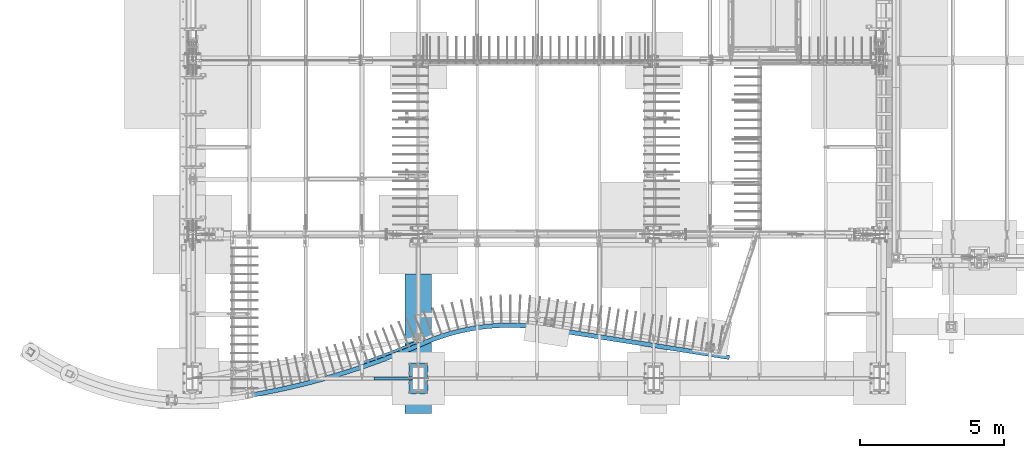
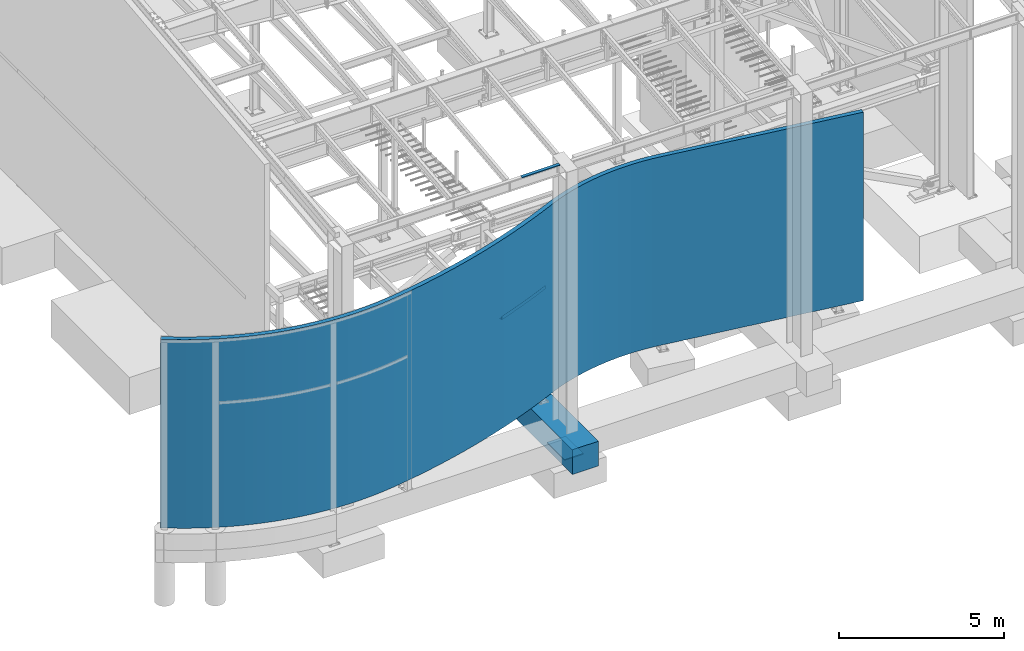
# One storey, part 704 of 1179: 5 beams, 5 elements without a shape of their own.
"""IFC2X3 building model written with IfcOpenShell, lengths in millimetres."""

from ifc_helpers import new_model, si_unit, frame, origin_with_axes, place, context, subcontext, project, spatial, faceted_brep, material, type_object, element, aggregate, save


model = new_model("IFC2X3")

# Units and contexts
model_context = context("Model", 3, precision=1e-05, world=origin_with_axes())
body_context = subcontext(model_context, "Body", "Model", "MODEL_VIEW")
ifc_project = project(units=[si_unit("LENGTHUNIT", "METRE", prefix="MILLI"), si_unit("AREAUNIT", "SQUARE_METRE"), si_unit("VOLUMEUNIT", "CUBIC_METRE"), si_unit("MASSUNIT", "GRAM", prefix="KILO"), si_unit("TIMEUNIT", "SECOND"), si_unit("PLANEANGLEUNIT", "RADIAN"), si_unit("SOLIDANGLEUNIT", "STERADIAN"), si_unit("THERMODYNAMICTEMPERATUREUNIT", "DEGREE_CELSIUS"), si_unit("LUMINOUSINTENSITYUNIT", "LUMEN")], contexts=[model_context])

# Site, building, storey
site_placement = place(None, origin_with_axes())
site = spatial("IfcSite", under=ifc_project, at=site_placement, CompositionType="ELEMENT")
building_placement = place(site_placement, origin_with_axes())
building = spatial("IfcBuilding", under=site, at=building_placement, Name="Undefined", CompositionType="ELEMENT")
storey_placement = place(building_placement, origin_with_axes())
storey = spatial("IfcBuildingStorey", under=building, at=storey_placement, Name="Undefined", CompositionType="ELEMENT", Elevation=0.0)

# Assembly, beam
assembly_1_placement = place(storey_placement, origin_with_axes())
assembly_1 = element("IfcElementAssembly", 1, at=assembly_1_placement, inside=storey, Name="BEAM", AssemblyPlace="NOTDEFINED", PredefinedType="RIGID_FRAME")
ifc_material_1 = material(Name="STEEL/A36")
beam_type_1 = type_object("IfcBeamType", PredefinedType="NOTDEFINED")
beam_1_placement = place(assembly_1_placement, frame((7404.09999999923, 485.774999119926, 9265.24531304499), z_axis=(-1.0, 0.0, 0.0), x_axis=(0.0, 0.0, 1.0)))
beam_1 = element("IfcBeam", 2, at=beam_1_placement, type_object=beam_type_1, material=ifc_material_1, Name="BENT_PLATE", context=body_context, shape_type="Brep", body=[
    faceted_brep([(-2.18278728425503e-11, -3.17500000000001, -663.575), (-2.18278728425503e-11, -3.17500000000001, 663.575), (2.18278728425503e-11, 3.17500000000001, 663.575), (2.18278728425503e-11, 3.17500000000001, -663.575), (36.8806648298032, 3.17499999974928, 663.575), (36.8806648298032, 3.17499999974928, -663.575), (29.7727112124448, -3.17500000020243, -663.575), (29.7727112124448, -3.17500000020243, 663.575), (25.3999996229504, -98.4249984738682, 663.575), (25.3999996229504, -98.4249984738682, -663.575), (19.7271291780035, -92.0749984738682, -663.575), (19.7271291780035, -92.0749984738682, 663.575), (9.29503585211933e-09, -98.4249984738682, 663.575), (9.29503585211933e-09, -98.4249984738682, -663.575), (9.29503585211933e-09, -92.0749984738682, 663.575), (9.29503585211933e-09, -92.0749984738682, -663.575)], [[[0, 1, 2, 3]], [[3, 2, 4, 5]], [[1, 0, 6, 7]], [[5, 4, 8, 9]], [[7, 6, 10, 11]], [[9, 8, 12, 13]], [[8, 4, 2, 1, 7, 11, 14, 12]], [[11, 10, 15, 14]], [[10, 6, 0, 3, 5, 9, 13, 15]], [[14, 15, 13, 12]]]),
])
aggregate(assembly_1, [beam_1])

assembly_2_placement = place(storey_placement, origin_with_axes())
assembly_2 = element("IfcElementAssembly", 3, at=assembly_2_placement, inside=storey, Name="BENT_PLATE", AssemblyPlace="NOTDEFINED", PredefinedType="RIGID_FRAME")
beam_type_2 = type_object("IfcBeamType", PredefinedType="NOTDEFINED")
beam_2_placement = place(assembly_2_placement, frame((8277.41144915615, 1723.22809377276, 3914.775), z_axis=(0.0, 0.0, 1.0), x_axis=(-0.925577876911731, -0.378557252963898, 0.0)))
beam_2 = element("IfcBeam", 4, at=beam_2_placement, type_object=beam_type_2, material=ifc_material_1, Name="BENT_PLATE", context=body_context, shape_type="Brep", body=[
    faceted_brep([(2.08746570688345, -50.7785532823825, -66.6750000000002), (2.08746570688345, -50.7785532823825, -60.3249999999998), (0.130466611703014, 44.4513404198469, -60.3249999999998), (0.130466611703014, 44.4513404198469, 66.6750000000002), (6.91215973347425e-11, 50.8000000000129, 66.6750000000002), (6.91215973347425e-11, 50.8000000000129, -66.6750000000002), (836.585317878429, 47.8884872559115, 66.6750000000002), (1254.74210741231, 39.2949292793146, 66.6750000000002), (1672.70114584619, 23.8290939184487, 66.6750000000002), (2090.34949706464, 1.49516017461906, 66.6750000000002), (2090.7406864984, 7.83309917928432, 66.6750000000002), (1672.98810276561, 30.1726068037783, 66.6750000000002), (1254.92475427918, 45.6423019737458, 66.6750000000002), (836.663605339998, 54.2380046449221, 66.6750000000002), (418.317673696302, 55.957392184753, 66.6750000000002), (418.34376679398, 49.6074457951997, 66.6750000000002), (418.317673696302, 55.957392184753, -66.6750000000002), (836.663605339998, 54.2380046449221, -66.6750000000002), (1254.92475427918, 45.642301973746, -66.6750000000002), (1672.98810276561, 30.1726068037783, -66.6750000000002), (2090.7406864984, 7.83309917928432, -66.6750000000002), (2084.48165555826, -93.5739248954135, -66.6750000000002), (1668.39679205482, -71.3235993615413, -66.6750000000002), (1252.00240440925, -55.9156611371529, -66.6750000000002), (835.411005954909, -47.3542735792475, -66.6750000000002), (418.735163259149, -45.6417500481423, -66.6750000000002), (418.735163259149, -45.6417500481423, -60.3249999999998), (835.411005954909, -47.3542735792475, -60.3249999999998), (1252.00240440925, -55.9156611371529, -60.3249999999998), (1668.39679205482, -71.3235993615413, -60.3249999999998), (2084.48165555826, -93.5739248954135, -60.3249999999998), (2090.34949706464, 1.49516017461906, -60.3249999999998), (1672.70114584619, 23.8290939184487, -60.3249999999998), (1254.74210741231, 39.2949292793146, -60.3249999999998), (836.585317878429, 47.8884872559115, -60.3249999999998), (418.34376679398, 49.6074457951997, -60.3249999999998)], [[[0, 1, 2, 3, 4, 5]], [[6, 7, 8, 9, 10, 11, 12, 13, 14, 4, 3, 15]], [[5, 4, 14, 16]], [[17, 18, 19, 20, 21, 22, 23, 24, 25, 0, 5, 16]], [[1, 0, 25, 26]], [[27, 28, 29, 30, 31, 32, 33, 34, 35, 2, 1, 26]], [[3, 2, 35, 15]], [[35, 34, 6, 15]], [[25, 24, 27, 26]], [[14, 13, 17, 16]], [[34, 33, 7, 6]], [[24, 23, 28, 27]], [[13, 12, 18, 17]], [[33, 32, 8, 7]], [[23, 22, 29, 28]], [[12, 11, 19, 18]], [[9, 31, 30, 21, 20, 10]], [[32, 31, 9, 8]], [[22, 21, 30, 29]], [[11, 10, 20, 19]]]),
])
aggregate(assembly_2, [beam_2])

assembly_3_placement = place(storey_placement, origin_with_axes())
assembly_3 = element("IfcElementAssembly", 5, at=assembly_3_placement, inside=storey, Name="STUD_WALL", AssemblyPlace="NOTDEFINED", PredefinedType="REINFORCEMENT_UNIT")
ifc_material_2 = material(Name="CONCRETE/5000")
beam_type_3 = type_object("IfcBeamType", PredefinedType="NOTDEFINED")
beam_3_placement = place(assembly_3_placement, frame((-5280.93505492762, 1414.62511079315, 3479.80000162176), z_axis=(0.554915501266417, 0.831906717399398, 0.0), x_axis=(0.831906717399398, -0.554915501266417, 0.0)))
beam_3 = element("IfcBeam", 6, at=beam_3_placement, type_object=beam_type_3, material=ifc_material_2, Name="STUD_WALL", context=body_context, shape_type="Brep", body=[
    faceted_brep([(-4.45015757577494e-09, -3479.8, -76.2000000000114), (4.45197656517848e-09, -3479.8, 76.2000000000103), (4.45197656517848e-09, 3479.8, 76.2000000000103), (-4.45015757577494e-09, 3479.8, -76.2000000000114), (126.051372758738, -3479.8, 76.1999999927286), (126.051372758738, 3479.8, 76.1999999927286), (127.946989991418, 3479.8, -76.200000007402), (127.946989991418, -3479.8, -76.200000007402), (505.254832719005, -3479.79998484933, 85.6348536014727), (505.25483271809, 3479.80001515067, 85.63485360145), (510.47957232354, 3479.80001515067, -66.6823154502608), (510.479572324455, -3479.79998484933, -66.6823154502379), (506.250983993699, -3479.79998484664, 85.6784140942232), (506.250983993699, 3479.80001515336, 85.6784140942232), (512.908889418409, 3479.80001515259, -66.5760843812752), (512.908889416906, -3479.79998484664, -66.5760843463186), (756.364295810306, -3479.79998484588, 99.7145330029075), (756.364295815061, 3479.80001515412, 99.7145329330922), (766.783297877615, 3479.80001515259, -52.3288963758575), (766.783297872858, -3479.79998484741, -52.3288963060397), (1020.22801920236, 3479.80001515183, -31.8112866587292), (1020.22801637489, -3479.79998484741, -31.8112868174223), (1006.05428344045, -3479.79998484588, 119.928178367833), (1006.0542834469, 3479.80001515412, 119.928178298151), (1007.04552919101, -3479.79998484592, 120.020769032081), (1007.04573871369, 3479.80001515408, 120.020788462685), (1022.17416335113, 3479.80001515024, -31.6295005467034), (1022.17395382846, -3479.79998484976, -31.6295199773083), (1257.97487043034, -3479.79999989839, 146.648608242431), (1257.97507844715, 3479.80000010161, 146.648627513304), (1276.41335730422, 3479.79999989839, -4.6504300875356), (1276.4131492874, -3479.80000010161, -4.65044935840865), (1633.0453080844, -3479.79999989839, 198.286736451165), (1633.04530949312, 3479.80000010161, 198.286727277003), (1656.17848280736, 3479.79999989839, 47.6340430971738), (1656.17848139864, -3479.80000010161, 47.6340522713353), (1881.36402800685, -3479.79999989839, 240.378299832771), (1881.36402967164, 3479.80000010161, 240.378290702091), (1908.70242538371, 3479.79999989839, 90.4384178042574), (1908.70242371892, -3479.80000010161, 90.4384269349373), (2129.02415291697, -3479.79999989839, 288.72408376661), (2129.02415478006, 3479.80000010161, 288.724074674431), (2159.61839334354, 3479.79999989839, 139.419775529436), (2159.61839148044, -3479.80000010161, 139.419784621615), (2251.80494217468, -3479.79999989839, 315.079091013039), (2251.80494420697, 3479.80000010161, 315.079081957629), (2285.17922054536, 3479.79999989839, 166.371520430513), (2285.17921851306, -3479.80000010161, 166.371529485924), (2497.71987675699, -3479.79999989839, 372.684160617364), (2497.71987895799, 3479.80000010161, 372.684151600904), (2533.86257675964, 3479.79999989839, 224.625087129713), (2533.86257455863, -3479.80000010161, 224.625096146172), (2619.66169759789, -3479.79999989839, 403.659463606977), (2619.66169993871, 3479.80000010161, 403.659454626221), (2658.10091757583, 3479.79999989839, 256.183745375045), (2658.10091523502, -3479.80000010161, 256.183754355802), (2741.43774954483, -3479.79999989839, 436.210208266087), (2741.43775199706, 3479.80000010161, 436.210199315518), (2781.70822129543, 3479.79999989839, 289.223983723224), (2781.7082188432, -3479.80000010161, 289.223992673792), (2862.79953335704, -3479.79999989839, 470.273021284595), (2862.79953592036, 3479.80000010161, 470.273012365336), (2904.89502719707, 3479.79999989839, 323.799028716661), (2904.89502463375, -3479.80000010161, 323.799037635921), (2983.72827477281, -3479.79999989839, 505.842633336556), (2983.72827744692, 3479.80000010161, 505.842624449712), (3027.64227868865, 3479.79999989839, 359.90353178901), (3027.64227601455, -3479.80000010161, 359.903540675853), (3104.20526653533, -3479.79999989839, 542.91354188325), (3104.20526931967, 3479.80000010161, 542.913533030639), (3149.93098713522, 3479.79999989839, 397.531907637643), (3149.93098435088, -3479.80000010161, 397.531916490255), (3105.62597964405, 3479.80000010161, 543.370106088282), (3105.62597680517, -3479.79999989839, 543.370114923779), (3224.2123307949, -3479.79999989839, 581.47861210888), (3224.21233369075, 3479.80000010161, 581.478603291186), (3152.25401609082, -3479.80000010161, 398.278468188439), (3152.2540189297, 3479.79999989839, 398.278459352942), (3271.74177580416, 3479.79999986953, 436.679734047501), (3271.74177249685, -3479.80000010161, 436.679744117801), (3402.60446380468, -3479.7999961091, 641.876752145114), (3402.6042044987, 3479.8000038909, 641.876651769853), (3452.81622657386, 3479.80000368649, 497.986023725056), (3452.81648587985, -3479.7999963135, 497.986124100319), (3632.72042573193, 3479.80001505059, 562.646715997594), (3632.7206798051, -3479.79998486396, 562.646815841956), (3579.84341834028, -3479.79998482918, 705.579510562174), (3579.84289771132, 3479.8000151708, 705.579316262686), (3580.77686944984, -3479.79998474469, 705.924840486235), (3580.77707011089, 3479.80001525531, 705.924904712314), (3634.55361806364, 3479.800015049, 563.324896721719), (3634.5534174026, -3479.799984951, 563.324832495641), (3816.54029937483, -3479.79999981138, 796.533001691813), (3816.54049875883, 3479.80000018862, 796.533065427483), (3872.98151415588, 3479.79999981138, 654.957060590377), (3872.98131477188, -3479.80000018862, 654.956996854707), (4049.53598789122, -3479.79999981138, 892.795037439216), (4049.53599466782, 3479.80000018862, 892.795021598136), (4109.48097084827, 3479.79999981138, 752.666676159091), (4109.48096407168, -3479.80000018862, 752.666692000171), (4280.28186298692, -3479.79999981138, 994.918459685776), (4280.28187010673, 3479.80000018862, 994.918443995831), (4343.26032737789, 3479.79999981138, 856.132655472181), (4343.26032025808, -3479.80000018862, 856.132671162125), (4394.14725204166, -3479.79999981138, 1047.8748736175), (4394.14725945264, 3479.80000018862, 1047.87485806373), (4459.70388945817, 3479.79999981138, 910.288123823741), (4459.70388204719, -3479.80000018862, 910.288139377511), (4620.92282795029, -3479.79999981138, 1158.53512128176), (4620.92283569843, 3479.80000018862, 1158.5351058922), (4689.46075162057, 3479.79999981138, 1022.40315723292), (4689.46074387243, -3479.80000018862, 1022.40317262248), (4844.66547458684, -3479.79999981138, 1274.69253957469), (4844.66548271459, 3479.80000018862, 1274.69252438404), (4916.56820675451, 3479.79999981138, 1140.30743726364), (4916.56819862676, -3479.80000018862, 1140.30745245429), (5065.44971378581, -3479.79999981138, 1396.37917589719), (5065.44972228987, 3479.80000018862, 1396.37916091168), (5140.67276371935, 3479.79999981138, 1263.82408781816), (5140.6727552153, -3479.80000018862, 1263.82410280367), (5283.1389325161, -3479.79999981138, 1523.51973510925), (5283.13894139022, 3479.80000018862, 1523.51972033995), (5361.6357549924, 3479.79999981138, 1392.87668141703), (5361.63574611827, -3479.80000018862, 1392.87669618633), (5497.59843276314, -3479.79999981138, 1656.03554734695), (5497.59844200147, 3479.80000018862, 1656.0355328036), (5579.32045687075, 3479.79999981138, 1527.38536509899), (5579.32044763243, -3479.80000018862, 1527.38537964234), (5708.69551500291, -3479.79999981138, 1793.84461678008), (5708.69552460001, 3479.80000018862, 1793.84460247117), (5793.59217419674, 3479.79999981138, 1667.26690991844), (5793.59216459964, -3479.80000018862, 1667.26692422736), (5916.29956019503, -3479.79999981138, 1936.86167226958), (5916.29957014449, 3479.80000018862, 1936.86165820461), (6004.31832357406, 3479.79999981138, 1812.4347623606), (6004.31831362459, -3479.80000018862, 1812.43477642558), (6120.66836982787, -3479.79998465921, 2085.27872990029), (6120.66838003779, 3479.80001534079, 2085.27871602508), (6210.9967963537, 3479.80001496354, 1962.52914741275), (6210.99678614378, -3479.79998503646, 1962.52916128796), (6121.46657775546, -3479.79998465801, 2085.87388922141), (6121.46658805392, 3479.80001534199, 2085.87387540996), (6212.56369493923, 3479.80001499298, 1963.69745901467), (6212.56368541513, -3479.79998503526, 1963.69747179133), (6320.52025549278, -3479.79999972657, 2238.15770555475), (6320.52092795554, 3479.80000027338, 2238.15820157918), (6414.61099601097, 3479.79999981138, 2118.2715137735), (6414.61065693306, -3479.80000027351, 2118.2712744759), (6320.91109067225, 3479.80000018863, 2238.47024353247), (6320.91107994971, -3479.79999981137, 2238.47025701794), (6418.8015382349, -3479.79999981137, 2316.28614974135), (6418.80154895744, 3479.80000018863, 2316.28613625588), (6415.74521345905, -3479.80000018863, 2119.17127495385), (6415.74522418159, 3479.79999981137, 2119.17126146838), (6513.63568246678, 3479.79999981137, 2196.98715419179), (6513.63567174423, -3479.80000018863, 2196.98716767726), (6419.19293909468, -3479.79999981137, 2316.59728534997), (6419.19294989953, 3479.80000018863, 2316.59727192993), (6514.76900093186, 3479.79999981137, 2197.8880610794), (6514.76899012701, -3479.80000018863, 2197.88807449945), (6516.51570354788, -3479.79999981137, 2395.95712824299), (6516.51571460164, 3479.80000018863, 2395.95711502633), (6614.29539707548, 3479.79999981137, 2279.0448100279), (6614.29538602172, -3479.80000018863, 2279.04482324456), (6803.89920732831, -3479.79999981137, 2642.44934129435), (6803.89921878792, 3479.80000018863, 2642.44932842586), (6905.26924939749, 3479.79999981137, 2528.61650727382), (6905.26923793789, -3479.80000018863, 2528.61652014231), (7240.14248101114, -3479.79999723655, 3045.7242497319), (7240.14249278474, 3479.80000276345, 3045.72423715247), (7344.28490260188, 3479.8000023862, 2934.45427722605), (7344.28489082828, -3479.7999976138, 2934.45428980548), (7240.86719046394, -3479.79999723635, 3046.41098041554), (7240.86720231317, 3479.80000276365, 3046.41096791117), (7345.69266553957, 3479.80000238787, 2935.78826572199), (7345.69265373446, -3479.79999761361, 2935.78827817903), (7561.13102934516, -3479.799997278, 3355.18335208735), (7561.13104222318, 3479.800002722, 3355.18334075432), (7667.85122888971, 3479.80000234746, 3246.3873768684), (7667.8512160117, -3479.79999765254, 3246.38738820142), (7984.59798223338, 3479.80000222623, 3562.50356125615), (7984.59796825638, -3479.79999777377, 3562.50357149277), (7876.01488687761, -3479.79999739851, 3669.44034925561), (7876.0149008546, 3479.80000260149, 3669.44033901899), (8295.83845766682, 3479.80000202421, 3884.04253904514), (8295.83844260995, -3479.79999797579, 3884.04254816654), (8185.42485080036, -3479.79999759934, 3989.08824652547), (8185.42486585723, 3479.80000240066, 3989.08823740407), (8601.47982950283, 3479.80000174147, 4210.90841307888), (8601.47981338551, -3479.79999825853, 4210.90842106657), (8489.26864136577, -3479.79999788042, 4314.03171074436), (8489.2686574831, 3479.80000211958, 4314.03170275667), (8901.43094195473, 3479.80000137809, 4543.00369748458), (8901.43092479668, -3479.79999862191, 4543.00370432042), (8787.45563890547, -3479.79999824166, 4644.17382938722), (8787.45565606351, 3479.80000175834, 4644.17382255138), (9195.60233632307, 3479.80000093418, 4880.22934674784), (9195.60231814434, -3479.79999906582, 4880.22935241402), (9079.89691085716, -3479.79999868296, 4979.41613946011), (9079.89692903589, 3479.80000131704, 4979.41613379393), (9483.9062776762, 3479.80000040987, 5222.48478525235), (9483.90625849714, -3479.79999959014, 5222.48478973141), (9366.50523828829, -3479.79999920419, 5319.65865686626), (9366.50525746734, 3479.80000079581, 5319.6586523872), (9766.2567776701, 3479.7999998112, 5569.6679335154), (9766.25676085758, -3479.80000019469, 5569.6679405504), (9647.19514190819, -3479.79999980519, 5664.79990622531), (9647.19516206604, 3479.80000019481, 5664.79990294934), (11179.7674425007, -3479.80053558057, 7797.20376488578), (11179.7263108748, 3479.79946424746, 7797.23025581147), (10939.5615612186, -3479.80044629763, 7431.12161312064), (11307.873065508, 3479.79999981137, 7714.69766496214), (11307.8933339325, -3479.79946424674, 7714.68397366108), (11066.2328831999, 3479.80044629823, 7346.45927218533), (10939.5276673159, 3479.79955358297, 7431.14426652978), (10693.1699256857, -3479.8003570099, 7069.17395323697), (11066.2667771025, -3479.79955358237, 7346.43661877619), (10818.3910795423, 3479.80035701038, 6982.366787396), (10693.1431252577, 3479.7996429137, 7069.19253212138), (10440.6636832799, -3479.8002677174, 6711.46529606992), (10818.4178799703, -3479.79964291322, 6982.34820851159), (10564.3983535524, 3479.80026771776, 6622.53814302066), (10440.6438261352, 3479.79973223964, 6711.4795672478), (10182.1157469434, -3479.80017842011, 6358.09892841062), (10564.4182106971, -3479.79973223928, 6622.52387184279), (10304.3280435455, 3479.80017842035, 6267.07724071185), (10182.1026770376, 3479.79982156081, 6358.10866266044), (9917.60077413083, -3479.80008911805, 6009.17688318429), (10304.3411134513, -3479.79982156057, 6267.06750646203), (10038.255242759, 3479.80008911817, 5916.08672097178), (10038.2616872317, -3479.79991087708, 5916.08174878006), (9917.59432965817, 3479.7999108772, 6009.181855376), (11180.2841444097, -3479.79999981137, 7798.05123789008), (11180.2841589488, 3479.80000018863, 7798.05122864797), (11308.9004095122, 3479.79999981137, 7716.29281441432), (11308.9003949732, -3479.80000018863, 7716.29282365644), (11180.8194142497, -3479.79999981137, 7798.90442785328), (11180.819428846, 3479.80000018863, 7798.90441870051), (11309.9163932066, 3479.79999990077, 7717.91224285269), (11309.9163820673, -3479.80000018863, 7717.91224983413), (11310.7385752459, -3479.79999982838, 7998.92000310728), (11310.7385804747, 3479.80000017162, 7998.91999451948), (11437.2206304749, 3479.79999997172, 7913.90204919214), (11437.2206252461, -3479.80000002828, 7913.90205777987), (11570.6344695531, 3479.80000018415, 8105.78514005555), (11570.6344668938, -3479.79999981584, 8105.78515233903), (11446.892830193, -3479.79999961158, 8194.74451017487), (11446.8928328523, 3479.80000038842, 8194.74449789132), (11710.0255372367, 3479.80000053788, 8293.37112904964), (11710.025537262, -3479.79999946212, 8293.37114494612), (11589.1470903049, -3479.7999992506, 8386.18364982113), (11589.1470902795, 3479.8000007494, 8386.18363392458), (11855.2555297172, 3479.80000103254, 8476.4738933679), (11855.2555325395, -3479.79999896746, 8476.47391279104), (11737.3602109135, -3479.79999874578, 8573.04747614372), (11737.3602080911, 3479.80000125422, 8573.04745672051), (12006.1803498051, 3479.80000166764, 8654.91175845908), (12006.1803555342, -3479.79999833236, 8654.91178131905), (11891.38513497, -3479.79999809764, 8755.1505828659), (11891.3851292408, 3479.80000190236, 8755.15056000586), (12162.6502499035, 3479.80000244256, 8828.50767828465), (12162.6502586461, -3479.79999755744, 8828.50770448819), (12051.0690389543, -3479.79999730681, 8932.31228729662), (12051.0690302116, 3479.80000269319, 8932.31226109301), (12324.5099805872, 3479.80000335653, 8997.08941098384), (12324.5099924472, -3479.79999664347, 8997.08944043439), (12216.253484507, -3479.79999637408, 9104.35680960384), (12216.2534726469, 3479.80000362592, 9104.35678015323), (12491.5989446416, 3479.80000440863, 9160.48968977208), (12491.5989597198, -3479.79999559137, 9160.48972236985), (12386.7745756316, -3479.79999530037, 9271.11344722337), (12386.7745605534, 3479.80000469963, 9271.11341462554), (12663.7513564072, 3479.80000559783, 9318.54638890299), (12663.751374801, -3479.79999440217, 9318.54642454507), (12562.4631213121, -3479.79999408675, 9432.41674422982), (12562.4631029182, 3479.80000591325, 9432.41670858768), (12840.7964062718, 3479.80000692294, 9471.10268452964), (12840.7964280754, -3479.79999307705, 9471.1027231101), (12743.1448033845, -3479.79999273442, 9588.10665550203), (12743.1447815808, 3479.80000726558, 9588.10661692152), (13022.5584301479, 3479.80000838266, 9618.00721030508), (13022.5584554523, -3479.79999161734, 9618.00725171507), (12928.6403494953, -3479.79999124473, 9738.02870551981), (12928.6403241909, 3479.80000875527, 9738.02866410977), (13208.857083767, 3479.80000997553, 9759.11420756807), (13208.8571126595, -3479.79999002447, 9759.11425169593), (13118.7657109753, -3479.79998961914, 9882.03414163455), (13118.7656820827, 3479.80001038085, 9882.03409750664), (13399.5075216166, 3479.80001169998, 9894.28366996478), (13399.5075541811, -3479.79998830002, 9894.28371669617), (13313.3322454527, -3479.79998785929, 10019.9800816616), (13313.3322128882, 3479.80001214071, 10019.9800349302), (13594.3205803442, 3479.80001355428, 10023.3814823631), (13594.3206166608, -3479.79998644572, 10023.3815315811), (13512.1469040243, -3479.7999859669, 10151.7296556479), (13512.1468677076, 3479.8000140331, 10151.7296064299), (13793.1029664453, 3479.80001553661, 10146.2795539217), (13793.1030065905, -3479.79998446339, 10146.2796055069), (13715.0124227982, -3479.79998394385, 10277.1521416744), (13715.0123826529, 3479.80001605615, 10277.1520900892), (13995.6574480488, 3479.800017645, 10262.8559451817), (13995.6574920952, -3479.799982355, 10262.8559990123), (13921.7275186196, -3479.79998179217, 10396.1230955584), (13921.727474573, 3479.80001820783, 10396.1230417277), (14201.7830506107, 3479.80001987735, 10372.994989055), (14201.7830986272, -3479.79998012265, 10372.995045007), (14132.0870887832, -3479.79997951397, 10508.5244743268), (14132.0870407666, 3479.80002048603, 10508.5244183748), (14411.2752563212, 3479.80002223145, 10476.5874055891), (14411.2753083726, -3479.79997776854, 10476.5874635365), (14345.8824145369, -3479.79997711152, 10614.2447533389), (14345.8823624854, 3479.80002288848, 10614.2446953914), (14623.9262456181, 3479.80002493024, 10573.5304386472), (14623.9262631756, -3479.79997529503, 10573.5304702103), (14562.9013681733, -3479.7999745872, 10713.1790369409), (14562.901312025, 3479.8000254128, 10713.1789771257), (14563.821334126, -3479.79997482155, 10713.5810406018), (14563.8213598779, 3479.80002517845, 10713.5810393492), (14626.1953955305, 3479.80002492358, 10574.5220323063), (14626.1953697786, -3479.79997507642, 10574.5220335589), (14564.7334293773, 3479.80002518133, 10714.0007726764), (14628.4449641694, 3479.8000249207, 10575.5572811918), (14628.4449344197, -3479.7999750793, 10575.5572806095), (14564.7333996276, -3479.79997481867, 10714.000772094), (20372.3225315885, 3479.80000013032, 13386.6465661131), (20436.0340663809, 3479.79999986968, 13248.2030746286), (20372.3225018388, -3479.79999986968, 13386.6465655308), (20436.0340366312, -3479.80000013032, 13248.2030740463)], [[[0, 1, 2, 3]], [[2, 1, 4, 5]], [[0, 3, 6, 7]], [[5, 4, 8, 9]], [[7, 6, 10, 11]], [[9, 8, 12, 13]], [[11, 10, 14, 15]], [[13, 12, 16, 17]], [[15, 14, 18, 19]], [[18, 20, 21, 19]], [[16, 22, 23, 17]], [[23, 22, 24, 25]], [[21, 20, 26, 27]], [[25, 24, 28, 29]], [[27, 26, 30, 31]], [[29, 28, 32, 33]], [[31, 30, 34, 35]], [[33, 32, 36, 37]], [[35, 34, 38, 39]], [[37, 36, 40, 41]], [[39, 38, 42, 43]], [[41, 40, 44, 45]], [[43, 42, 46, 47]], [[45, 44, 48, 49]], [[47, 46, 50, 51]], [[49, 48, 52, 53]], [[51, 50, 54, 55]], [[53, 52, 56, 57]], [[55, 54, 58, 59]], [[57, 56, 60, 61]], [[59, 58, 62, 63]], [[61, 60, 64, 65]], [[63, 62, 66, 67]], [[65, 64, 68, 69]], [[67, 66, 70, 71]], [[72, 69, 68, 73, 74, 75]], [[76, 71, 70, 77, 78, 79]], [[75, 74, 80, 81]], [[79, 78, 82, 83]], [[82, 84, 85, 83]], [[80, 86, 87, 81]], [[87, 86, 88, 89]], [[85, 84, 90, 91]], [[89, 88, 92, 93]], [[91, 90, 94, 95]], [[93, 92, 96, 97]], [[95, 94, 98, 99]], [[97, 96, 100, 101]], [[99, 98, 102, 103]], [[101, 100, 104, 105]], [[103, 102, 106, 107]], [[105, 104, 108, 109]], [[107, 106, 110, 111]], [[109, 108, 112, 113]], [[111, 110, 114, 115]], [[113, 112, 116, 117]], [[115, 114, 118, 119]], [[117, 116, 120, 121]], [[119, 118, 122, 123]], [[121, 120, 124, 125]], [[123, 122, 126, 127]], [[125, 124, 128, 129]], [[127, 126, 130, 131]], [[129, 128, 132, 133]], [[131, 130, 134, 135]], [[133, 132, 136, 137]], [[135, 134, 138, 139]], [[137, 136, 140, 141]], [[139, 138, 142, 143]], [[141, 140, 144, 145]], [[143, 142, 146, 147]], [[148, 145, 144, 149, 150, 151]], [[152, 147, 146, 153, 154, 155]], [[151, 150, 156, 157]], [[155, 154, 158, 159]], [[157, 156, 160, 161]], [[159, 158, 162, 163]], [[161, 160, 164, 165]], [[163, 162, 166, 167]], [[165, 164, 168, 169]], [[167, 166, 170, 171]], [[169, 168, 172, 173]], [[171, 170, 174, 175]], [[173, 172, 176, 177]], [[175, 174, 178, 179]], [[178, 180, 181, 179]], [[176, 182, 183, 177]], [[180, 184, 185, 181]], [[182, 186, 187, 183]], [[184, 188, 189, 185]], [[186, 190, 191, 187]], [[188, 192, 193, 189]], [[190, 194, 195, 191]], [[192, 196, 197, 193]], [[194, 198, 199, 195]], [[196, 200, 201, 197]], [[198, 202, 203, 199]], [[200, 204, 205, 201]], [[202, 206, 207, 203]], [[208, 209, 210]], [[211, 212, 213]], [[210, 214, 215]], [[213, 216, 217]], [[215, 218, 219]], [[217, 220, 221]], [[219, 222, 223]], [[221, 224, 225]], [[223, 226, 227]], [[225, 228, 229]], [[229, 230, 204]], [[227, 231, 206]], [[228, 224, 220, 215, 219, 223, 227, 206, 202, 198, 194, 190, 186, 182, 176, 172, 168, 164, 160, 156, 150, 149, 144, 140, 136, 132, 128, 124, 120, 116, 112, 108, 104, 100, 96, 92, 88, 86, 80, 74, 73, 68, 64, 60, 56, 52, 48, 44, 40, 36, 32, 28, 24, 22, 16, 12, 8, 4, 1, 0, 7, 11, 15, 19, 21, 27, 31, 35, 39, 43, 47, 51, 55, 59, 63, 67, 71, 76, 79, 83, 85, 91, 95, 99, 103, 107, 111, 115, 119, 123, 127, 131, 135, 139, 143, 147, 152, 155, 159, 163, 167, 171, 175, 179, 181, 185, 189, 193, 197, 201, 205, 230]], [[207, 206, 231]], [[226, 222, 218, 217, 221, 225, 229, 204, 200, 196, 192, 188, 184, 180, 178, 174, 170, 166, 162, 158, 154, 153, 146, 142, 138, 134, 130, 126, 122, 118, 114, 110, 106, 102, 98, 94, 90, 84, 82, 78, 77, 70, 66, 62, 58, 54, 50, 46, 42, 38, 34, 30, 26, 20, 18, 14, 10, 6, 3, 2, 5, 9, 13, 17, 23, 25, 29, 33, 37, 41, 45, 49, 53, 57, 61, 65, 69, 72, 75, 81, 87, 89, 93, 97, 101, 105, 109, 113, 117, 121, 125, 129, 133, 137, 141, 145, 148, 151, 157, 161, 165, 169, 173, 177, 183, 187, 191, 195, 199, 203, 207, 231]], [[205, 204, 230]], [[230, 229, 228]], [[231, 227, 226]], [[228, 225, 224]], [[226, 223, 222]], [[224, 221, 220]], [[222, 219, 218]], [[220, 217, 216]], [[218, 215, 214]], [[216, 213, 212]], [[214, 210, 209]], [[209, 208, 232, 233]], [[212, 211, 234, 235]], [[233, 232, 236, 237]], [[235, 234, 238, 239]], [[237, 236, 240, 241]], [[239, 238, 242, 243]], [[242, 244, 245, 243]], [[240, 246, 247, 241]], [[244, 248, 249, 245]], [[246, 250, 251, 247]], [[248, 252, 253, 249]], [[250, 254, 255, 251]], [[252, 256, 257, 253]], [[254, 258, 259, 255]], [[256, 260, 261, 257]], [[258, 262, 263, 259]], [[260, 264, 265, 261]], [[262, 266, 267, 263]], [[264, 268, 269, 265]], [[266, 270, 271, 267]], [[268, 272, 273, 269]], [[270, 274, 275, 271]], [[272, 276, 277, 273]], [[274, 278, 279, 275]], [[276, 280, 281, 277]], [[278, 282, 283, 279]], [[280, 284, 285, 281]], [[282, 286, 287, 283]], [[284, 288, 289, 285]], [[286, 290, 291, 287]], [[288, 292, 293, 289]], [[290, 294, 295, 291]], [[292, 296, 297, 293]], [[294, 298, 299, 295]], [[296, 300, 301, 297]], [[298, 302, 303, 299]], [[300, 304, 305, 301]], [[302, 306, 307, 303]], [[304, 308, 309, 305]], [[306, 310, 311, 307]], [[308, 312, 313, 309]], [[310, 314, 315, 311]], [[315, 314, 316, 317]], [[313, 312, 318, 319]], [[318, 312, 308, 304, 300, 296, 292, 288, 284, 280, 276, 272, 268, 264, 260, 256, 252, 248, 244, 242, 238, 234, 211, 213, 217, 218, 214, 209, 233, 237, 241, 247, 251, 255, 259, 263, 267, 271, 275, 279, 283, 287, 291, 295, 299, 303, 307, 311, 315, 317, 320, 321]], [[316, 314, 310, 306, 302, 298, 294, 290, 286, 282, 278, 274, 270, 266, 262, 258, 254, 250, 246, 240, 236, 232, 208, 210, 215, 220, 216, 212, 235, 239, 243, 245, 249, 253, 257, 261, 265, 269, 273, 277, 281, 285, 289, 293, 297, 301, 305, 309, 313, 319, 322, 323]], [[321, 320, 324, 325]], [[320, 317, 316, 323, 326, 324]], [[323, 322, 327, 326]], [[322, 319, 318, 321, 325, 327]], [[326, 327, 325, 324]]]),
])
aggregate(assembly_3, [beam_3])

assembly_4_placement = place(storey_placement, origin_with_axes())
assembly_4 = element("IfcElementAssembly", 7, at=assembly_4_placement, inside=storey, Name="GRADE_BEAM", AssemblyPlace="NOTDEFINED", PredefinedType="REINFORCEMENT_UNIT")
beam_type_4 = type_object("IfcBeamType", PredefinedType="NOTDEFINED")
beam_4_placement = place(assembly_4_placement, frame((8280.4, -781.049999999989, -889.0), z_axis=(0.0, 0.0, 1.0), x_axis=(0.0, 1.0, 0.0)))
beam_4 = element("IfcBeam", 8, at=beam_4_placement, type_object=beam_type_4, material=ifc_material_2, Name="GRADE_BEAM", context=body_context, shape_type="Brep", body=[
    faceted_brep([(4.84305928694084e-11, 457.2, -457.2), (4.84305928694084e-11, 457.2, 457.2), (4845.05, 457.2, 457.2), (4845.05, 457.2, -457.2), (-4.82032191939652e-11, -457.2, 457.2), (4845.05, -457.200000000001, 457.2), (-4.82032191939652e-11, -457.2, -457.2), (4845.05, -457.200000000001, -457.2)], [[[0, 1, 2, 3]], [[1, 4, 5, 2]], [[4, 6, 7, 5]], [[6, 0, 3, 7]], [[5, 7, 3, 2]], [[6, 4, 1, 0]]]),
])
aggregate(assembly_4, [beam_4])

assembly_5_placement = place(storey_placement, origin_with_axes())
assembly_5 = element("IfcElementAssembly", 9, at=assembly_5_placement, inside=storey, Name="COLUMN", AssemblyPlace="NOTDEFINED", PredefinedType="RIGID_FRAME")
ifc_material_3 = material(Name="STEEL/A572-GR.50")
beam_type_5 = type_object("IfcBeamType", PredefinedType="NOTDEFINED")
beam_5_placement = place(assembly_5_placement, frame((8280.4, -95.25, -1276.35), z_axis=(-1.0, 0.0, 0.0), x_axis=(0.0, 1.0, 0.0)))
beam_5 = element("IfcBeam", 10, at=beam_5_placement, type_object=beam_type_5, material=ifc_material_3, context=body_context, shape_type="Brep", body=[
    faceted_brep([(0.0, 19.05, -330.200000000001), (0.0, 19.05, 330.2), (1066.80000000029, 19.05, 330.2), (1066.80000000029, 19.05, -330.200000000001), (0.0, -19.05, 330.2), (1066.80000000029, -19.05, 330.2), (0.0, -19.05, -330.200000000001), (1066.80000000029, -19.05, -330.200000000001)], [[[0, 1, 2, 3]], [[1, 4, 5, 2]], [[4, 6, 7, 5]], [[6, 0, 3, 7]], [[5, 7, 3, 2]], [[6, 4, 1, 0]]]),
])
aggregate(assembly_5, [beam_5])

save(model, "model.ifc")
